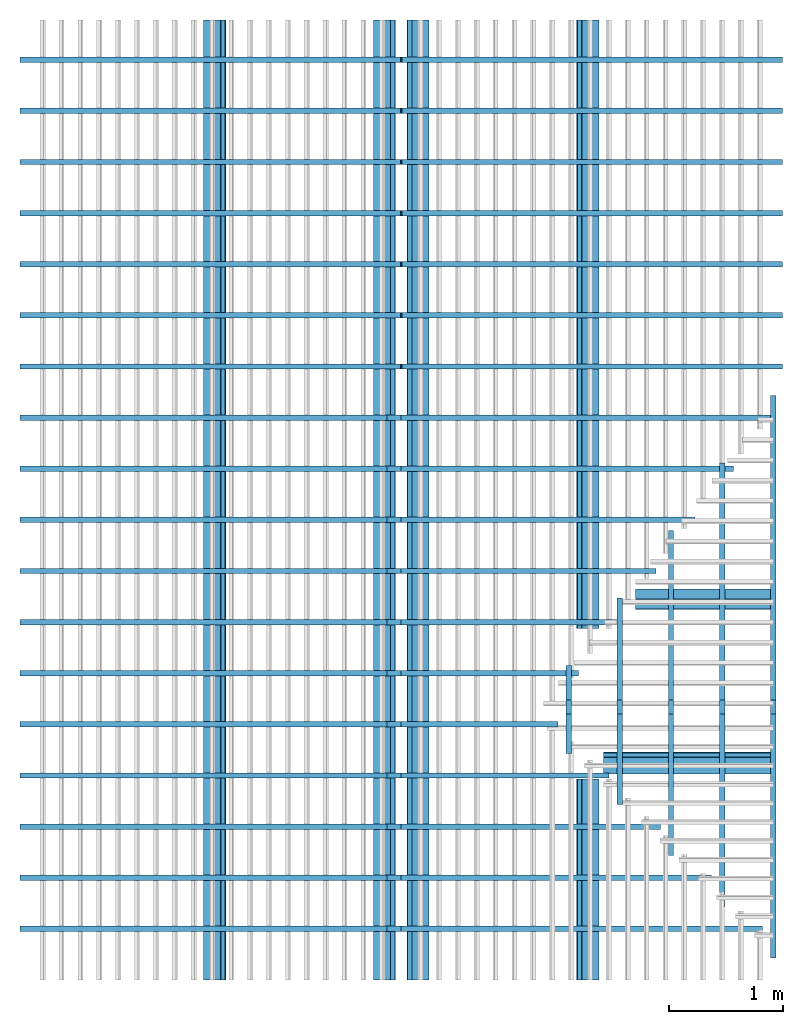
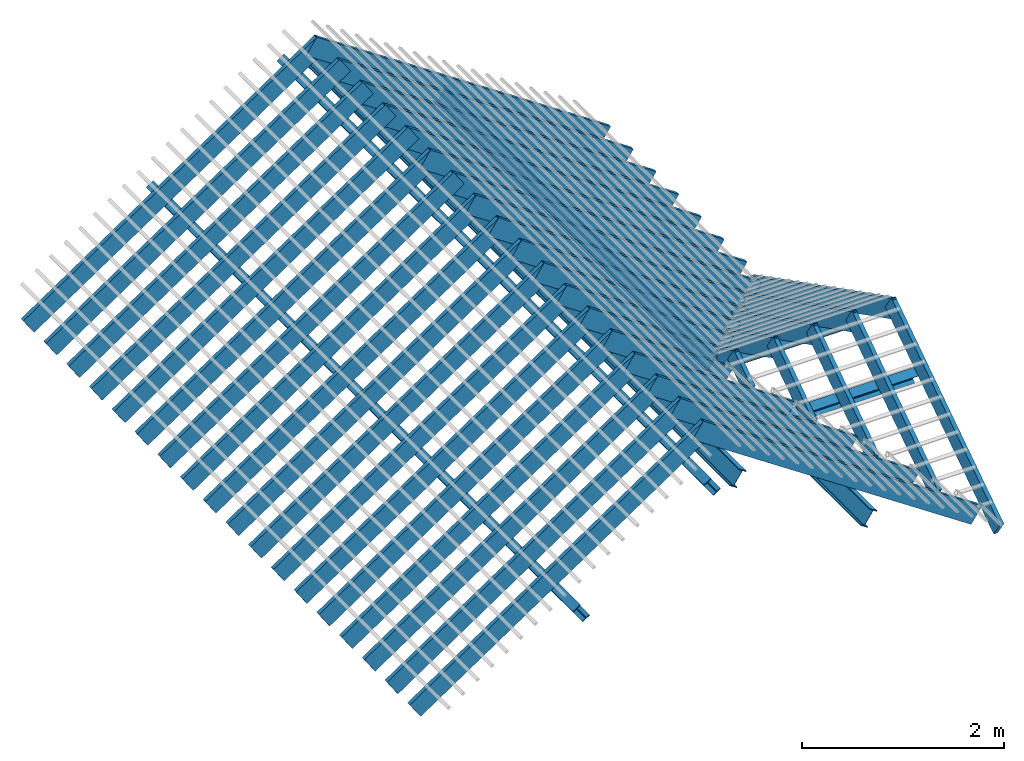
# One storey, part 1 of 3: 53 members, 10 elements without a shape of their own.
"""IFC4 building model written with IfcOpenShell, lengths in metres."""

from ifc_helpers import new_model, entity, si_unit, converted_unit, frame, frame_2d, origin_with_axes, origin_2d_with_axis, place, context, subcontext, project, library, spatial, rectangle, i_section, extrude, material, material_profile, profile_set, profile_usage, type_object, element, aggregate, save


model = new_model("IFC4")

# Units and contexts
model_context = context("Model", 3, precision=1e-05, world=origin_with_axes())
plan_context = context("Plan", 2, precision=1e-05, world=origin_2d_with_axis())
body_context = subcontext(model_context, "Body", "Model", "MODEL_VIEW")
ifc_project = project(units=[si_unit("LENGTHUNIT", "METRE"), converted_unit("PLANEANGLEUNIT", "degree", entity("IfcReal", 0.0174532925199433), si_unit("PLANEANGLEUNIT", "RADIAN"), dimensions=[0, 0, 0, 0, 0, 0, 0]), si_unit("AREAUNIT", "SQUARE_METRE"), si_unit("VOLUMEUNIT", "CUBIC_METRE")], contexts=[model_context, plan_context])
project_library_1 = library(declared=ifc_project)
project_library_2 = library(declared=ifc_project)
project_library_3 = library(declared=ifc_project)

# Site, building, storey
site_placement = place(None, frame((-0.0250487327575684, 0.0, 0.0), z_axis=(0.0, 0.0, 1.0), x_axis=(1.0, 0.0, 0.0)))
site = spatial("IfcSite", under=ifc_project, at=site_placement)
building_placement = place(site_placement, origin_with_axes())
building = spatial("IfcBuilding", under=site, at=building_placement, Name="Building")
storey_placement = place(building_placement, frame((0.0250487327575684, 0.0, 0.0), z_axis=(0.0, 0.0, 1.0), x_axis=(1.0, 0.0, 0.0)))
storey = spatial("IfcBuildingStorey", under=building, at=storey_placement, Name="Roof framing", CompositionType="ELEMENT", Elevation=0.0)

# Assemblies, members
assembly_1_placement = place(storey_placement, origin_with_axes())
assembly_1 = element("IfcElementAssembly", 1, at=assembly_1_placement, inside=storey, Name="purlins")
assembly_2_placement = place(assembly_1_placement, frame((1.27500009536743, -6.61744490042422e-24, 2.40000009536743), z_axis=(0.557621447781006, -6.78052809385821e-09, 0.830095368602075), x_axis=(1.21597333116231e-08, 1.0, -6.86638795477696e-25)))
assembly_2 = element("IfcElementAssembly", 2, at=assembly_2_placement, Name="purlins")
ifc_material_1 = material(Name="Hot Rolled Steel")
ifc_material_profile_1 = material_profile(ifc_material_1, i_section(OverallWidth=0.1, OverallDepth=0.2, WebThickness=0.005, FlangeThickness=0.01, FilletRadius=0.005, at=frame_2d((0.0, -0.25), x_axis=(1.0, 0.0))))
ifc_profile_set_1 = profile_set([ifc_material_profile_1])
ifc_profile_usage_1 = profile_usage(ifc_profile_set_1)
member_type_1 = type_object("IfcMemberType", Name="purlin", PredefinedType="PURLIN", material=ifc_profile_set_1)
member_1_placement = place(assembly_2_placement, frame((1.76917151168791, 1.8, 0.0), z_axis=(-1.0, 1.25507673201836e-16, 0.0), x_axis=(-1.25507673201836e-16, -1.0, 0.0)))
member_1 = element("IfcMember", 3, at=member_1_placement, type_object=member_type_1, material=ifc_profile_usage_1, Name="purlin", context=body_context, shape_type="SweptSolid", body=[
    extrude(i_section(OverallWidth=0.1, OverallDepth=0.2, WebThickness=0.005, FlangeThickness=0.01, FilletRadius=0.005, at=frame_2d((0.0, -0.25), x_axis=(1.0, 0.0))), origin_with_axes(), (0.0, 0.0, 1.0), 1.76917155151103),
])
ifc_profile_usage_2 = profile_usage(ifc_profile_set_1)
member_2_placement = place(assembly_2_placement, frame((8.44999980926514, 3.6, 0.0), z_axis=(-1.0, 0.0, 0.0), x_axis=(0.0, -1.0, 0.0)))
member_2 = element("IfcMember", 4, at=member_2_placement, type_object=member_type_1, material=ifc_profile_usage_2, Name="purlin", context=body_context, shape_type="SweptSolid", body=[
    extrude(i_section(OverallWidth=0.1, OverallDepth=0.2, WebThickness=0.005, FlangeThickness=0.01, FilletRadius=0.005, at=frame_2d((0.0, -0.25), x_axis=(1.0, 0.0))), origin_with_axes(), (0.0, 0.0, 1.0), 8.44999984908826),
])
ifc_profile_usage_3 = profile_usage(ifc_profile_set_1)
member_3_placement = place(assembly_2_placement, frame((8.44999980926514, 1.8, 0.0), z_axis=(-1.0, 0.0, 0.0), x_axis=(0.0, -1.0, 0.0)))
member_3 = element("IfcMember", 5, at=member_3_placement, type_object=member_type_1, material=ifc_profile_usage_3, Name="purlin", context=body_context, shape_type="SweptSolid", body=[
    extrude(i_section(OverallWidth=0.1, OverallDepth=0.2, WebThickness=0.005, FlangeThickness=0.01, FilletRadius=0.005, at=frame_2d((0.0, -0.25), x_axis=(1.0, 0.0))), origin_with_axes(), (0.0, 0.0, 1.0), 5.35502062257291),
])
aggregate(assembly_2, [member_1, member_2, member_3])
assembly_3_placement = place(assembly_1_placement, frame((-5.27499914169312, 0.0, 2.40000009536743), z_axis=(-0.557621451915285, 0.0, 0.830095365824849), x_axis=(0.0, -1.0, 0.0)))
assembly_3 = element("IfcElementAssembly", 6, at=assembly_3_placement, Name="purlins")
ifc_profile_usage_4 = profile_usage(ifc_profile_set_1)
member_4_placement = place(assembly_3_placement, frame((0.0, 1.8, 0.0), z_axis=(-1.0, 0.0, 0.0), x_axis=(0.0, -1.0, 0.0)))
member_4 = element("IfcMember", 7, at=member_4_placement, type_object=member_type_1, material=ifc_profile_usage_4, Name="purlin", context=body_context, shape_type="SweptSolid", body=[
    extrude(i_section(OverallWidth=0.1, OverallDepth=0.2, WebThickness=0.005, FlangeThickness=0.01, FilletRadius=0.005, at=frame_2d((0.0, -0.25), x_axis=(1.0, 0.0))), origin_with_axes(), (0.0, 0.0, 1.0), 8.44999980926514),
])
ifc_profile_usage_5 = profile_usage(ifc_profile_set_1)
member_5_placement = place(assembly_3_placement, frame((0.0, 3.6, 0.0), z_axis=(-1.0, 0.0, 0.0), x_axis=(0.0, -1.0, 0.0)))
member_5 = element("IfcMember", 8, at=member_5_placement, type_object=member_type_1, material=ifc_profile_usage_5, Name="purlin", context=body_context, shape_type="SweptSolid", body=[
    extrude(i_section(OverallWidth=0.1, OverallDepth=0.2, WebThickness=0.005, FlangeThickness=0.01, FilletRadius=0.005, at=frame_2d((0.0, -0.25), x_axis=(1.0, 0.0))), origin_with_axes(), (0.0, 0.0, 1.0), 8.44999980926514),
])
aggregate(assembly_3, [member_4, member_5])
assembly_4_placement = place(assembly_1_placement, frame((1.27500009536743, 5.06999969482422, 2.40000009536743), z_axis=(-1.8134071260532e-16, 0.453056810096847, 0.891481646936643), x_axis=(-1.0, -4.00260427751998e-16, -2.19767193434487e-32)))
assembly_4 = element("IfcElementAssembly", 9, at=assembly_4_placement, Name="purlins")
ifc_profile_usage_6 = profile_usage(ifc_profile_set_1)
member_6_placement = place(assembly_4_placement, frame((1.2139864578885, 1.8, 0.0), z_axis=(-1.0, 3.65810213955009e-16, 0.0), x_axis=(-3.65810213955009e-16, -1.0, 0.0)))
member_6 = element("IfcMember", 10, at=member_6_placement, type_object=member_type_1, material=ifc_profile_usage_6, Name="purlin", context=body_context, shape_type="SweptSolid", body=[
    extrude(i_section(OverallWidth=0.1, OverallDepth=0.2, WebThickness=0.005, FlangeThickness=0.01, FilletRadius=0.005, at=frame_2d((0.0, -0.25), x_axis=(1.0, 0.0))), origin_with_axes(), (0.0, 0.0, 1.0), 1.21398799953869),
])
aggregate(assembly_4, [member_6])
assembly_5_placement = place(assembly_1_placement, frame((1.27500009536743, 0.274999976158142, 2.40000009536743), z_axis=(-5.93234342970621e-17, -0.55762137886684, 0.830095414895567), x_axis=(1.0, -1.0638658513706e-16, 0.0)))
assembly_5 = element("IfcElementAssembly", 11, at=assembly_5_placement, Name="purlins")
aggregate(assembly_1, [assembly_2, assembly_3, assembly_4, assembly_5])
ifc_profile_usage_7 = profile_usage(ifc_profile_set_1)
member_7_placement = place(assembly_5_placement, frame((1.8974598461341e-06, 1.8, 0.0), z_axis=(-1.0, 2.97213871125409e-16, 0.0), x_axis=(-2.97213871125409e-16, -1.0, 0.0)))
member_7 = element("IfcMember", 12, at=member_7_placement, type_object=member_type_1, material=ifc_profile_usage_7, Name="purlin", context=body_context, shape_type="SweptSolid", body=[
    extrude(i_section(OverallWidth=0.1, OverallDepth=0.2, WebThickness=0.005, FlangeThickness=0.01, FilletRadius=0.005, at=frame_2d((0.0, -0.25), x_axis=(1.0, 0.0))), origin_with_axes(), (0.0, 0.0, 1.0), 1.49417390301639),
])
aggregate(assembly_5, [member_7])

assembly_6_placement = place(storey_placement, origin_with_axes())
assembly_6 = element("IfcElementAssembly", 13, at=assembly_6_placement, inside=storey, Name="joists")
assembly_7_placement = place(assembly_6_placement, frame((1.27500009536743, -6.61744490042422e-24, 2.40000009536743), z_axis=(0.557621447781006, -6.78052809385821e-09, 0.830095368602075), x_axis=(1.21597333116231e-08, 1.0, -6.86638795477696e-25)))
assembly_7 = element("IfcElementAssembly", 14, at=assembly_7_placement, Name="joists")
ifc_material_2 = material(Name="C24 Wood")
ifc_material_profile_2 = material_profile(ifc_material_2, rectangle(XDim=0.047, YDim=0.22, at=frame_2d((0.0, -0.04), x_axis=(1.0, 0.0))))
ifc_profile_set_2 = profile_set([ifc_material_profile_2])
ifc_profile_usage_8 = profile_usage(ifc_profile_set_2)
member_type_2 = type_object("IfcMemberType", Name="joist", PredefinedType="RAFTER", material=ifc_profile_set_2)
member_8_placement = place(assembly_7_placement, frame((0.45, 3.99532944546262, 0.0), z_axis=(-5.9457489813241e-17, -1.0, 0.0), x_axis=(1.0, -5.9457489813241e-17, 0.0)))
member_8 = element("IfcMember", 15, at=member_8_placement, type_object=member_type_2, material=ifc_profile_usage_8, Name="joist", context=body_context, shape_type="SweptSolid", body=[
    extrude(rectangle(XDim=0.047, YDim=0.22, at=frame_2d((0.0, -0.04), x_axis=(1.0, 0.0))), origin_with_axes(), (0.0, 0.0, 1.0), 3.83451024626981),
])
ifc_profile_usage_9 = profile_usage(ifc_profile_set_2)
member_9_placement = place(assembly_7_placement, frame((0.9, 3.99532944546262, 0.0), z_axis=(-3.47770234890074e-17, -1.0, 0.0), x_axis=(1.0, -3.47770234890074e-17, 0.0)))
member_9 = element("IfcMember", 16, at=member_9_placement, type_object=member_type_2, material=ifc_profile_usage_9, Name="joist", context=body_context, shape_type="SweptSolid", body=[
    extrude(rectangle(XDim=0.047, YDim=0.22, at=frame_2d((0.0, -0.04), x_axis=(1.0, 0.0))), origin_with_axes(), (0.0, 0.0, 1.0), 3.29240381505359),
])
ifc_profile_usage_10 = profile_usage(ifc_profile_set_2)
member_10_placement = place(assembly_7_placement, frame((1.35, 3.99532944546262, 0.0), z_axis=(-8.37810150208624e-17, -1.0, 0.0), x_axis=(1.0, -8.37810150208624e-17, 0.0)))
member_10 = element("IfcMember", 17, at=member_10_placement, type_object=member_type_2, material=ifc_profile_usage_10, Name="joist", context=body_context, shape_type="SweptSolid", body=[
    extrude(rectangle(XDim=0.047, YDim=0.22, at=frame_2d((0.0, -0.04), x_axis=(1.0, 0.0))), origin_with_axes(), (0.0, 0.0, 1.0), 2.75029738383737),
])
ifc_profile_usage_11 = profile_usage(ifc_profile_set_2)
member_11_placement = place(assembly_7_placement, frame((1.8, 3.99532944546262, 0.0), z_axis=(-1.05324711999622e-16, -1.0, 0.0), x_axis=(1.0, -1.05324711999622e-16, 0.0)))
member_11 = element("IfcMember", 18, at=member_11_placement, type_object=member_type_2, material=ifc_profile_usage_11, Name="joist", context=body_context, shape_type="SweptSolid", body=[
    extrude(rectangle(XDim=0.047, YDim=0.22, at=frame_2d((0.0, -0.04), x_axis=(1.0, 0.0))), origin_with_axes(), (0.0, 0.0, 1.0), 2.20819095262115),
])
ifc_profile_usage_12 = profile_usage(ifc_profile_set_2)
member_12_placement = place(assembly_7_placement, frame((2.25, 3.99532944546262, 0.0), z_axis=(-2.83566566031615e-16, -1.0, 0.0), x_axis=(1.0, -2.83566566031615e-16, 0.0)))
member_12 = element("IfcMember", 19, at=member_12_placement, type_object=member_type_2, material=ifc_profile_usage_12, Name="joist", context=body_context, shape_type="SweptSolid", body=[
    extrude(rectangle(XDim=0.047, YDim=0.22, at=frame_2d((0.0, -0.04), x_axis=(1.0, 0.0))), origin_with_axes(), (0.0, 0.0, 1.0), 1.66608452140494),
])
ifc_profile_usage_13 = profile_usage(ifc_profile_set_2)
member_13_placement = place(assembly_7_placement, frame((2.7, 3.99532944546262, 0.0), z_axis=(0.0, -1.0, 0.0), x_axis=(1.0, 0.0, 0.0)))
member_13 = element("IfcMember", 20, at=member_13_placement, type_object=member_type_2, material=ifc_profile_usage_13, Name="joist", context=body_context, shape_type="SweptSolid", body=[
    extrude(rectangle(XDim=0.047, YDim=0.22, at=frame_2d((0.0, -0.04), x_axis=(1.0, 0.0))), origin_with_axes(), (0.0, 0.0, 1.0), 1.88535216274302),
])
ifc_profile_usage_14 = profile_usage(ifc_profile_set_2)
member_14_placement = place(assembly_7_placement, frame((3.15, 3.99532944546262, 0.0), z_axis=(-2.02274822579913e-16, -1.0, 0.0), x_axis=(1.0, -2.02274822579913e-16, 0.0)))
member_14 = element("IfcMember", 21, at=member_14_placement, type_object=member_type_2, material=ifc_profile_usage_14, Name="joist", context=body_context, shape_type="SweptSolid", body=[
    extrude(rectangle(XDim=0.047, YDim=0.22, at=frame_2d((0.0, -0.04), x_axis=(1.0, 0.0))), origin_with_axes(), (0.0, 0.0, 1.0), 2.29547447470688),
])
ifc_profile_usage_15 = profile_usage(ifc_profile_set_2)
member_15_placement = place(assembly_7_placement, frame((3.6, 3.99532944546262, 0.0), z_axis=(-1.70436658550493e-16, -1.0, 0.0), x_axis=(1.0, -1.70436658550493e-16, 0.0)))
member_15 = element("IfcMember", 22, at=member_15_placement, type_object=member_type_2, material=ifc_profile_usage_15, Name="joist", context=body_context, shape_type="SweptSolid", body=[
    extrude(rectangle(XDim=0.047, YDim=0.22, at=frame_2d((0.0, -0.04), x_axis=(1.0, 0.0))), origin_with_axes(), (0.0, 0.0, 1.0), 2.70559678667074),
])
ifc_profile_usage_16 = profile_usage(ifc_profile_set_2)
member_16_placement = place(assembly_7_placement, frame((4.05, 3.99532944546262, 0.0), z_axis=(0.0, -1.0, 0.0), x_axis=(1.0, 0.0, 0.0)))
member_16 = element("IfcMember", 23, at=member_16_placement, type_object=member_type_2, material=ifc_profile_usage_16, Name="joist", context=body_context, shape_type="SweptSolid", body=[
    extrude(rectangle(XDim=0.047, YDim=0.22, at=frame_2d((0.0, -0.04), x_axis=(1.0, 0.0))), origin_with_axes(), (0.0, 0.0, 1.0), 3.11571909863461),
])
ifc_profile_usage_17 = profile_usage(ifc_profile_set_2)
member_17_placement = place(assembly_7_placement, frame((4.5, 3.99532944546262, 0.0), z_axis=(0.0, -1.0, 0.0), x_axis=(1.0, 0.0, 0.0)))
member_17 = element("IfcMember", 24, at=member_17_placement, type_object=member_type_2, material=ifc_profile_usage_17, Name="joist", context=body_context, shape_type="SweptSolid", body=[
    extrude(rectangle(XDim=0.047, YDim=0.22, at=frame_2d((0.0, -0.04), x_axis=(1.0, 0.0))), origin_with_axes(), (0.0, 0.0, 1.0), 3.52584141059847),
])
ifc_profile_usage_18 = profile_usage(ifc_profile_set_2)
member_18_placement = place(assembly_7_placement, frame((4.95, 3.99532944546262, 0.0), z_axis=(0.0, -1.0, 0.0), x_axis=(1.0, 0.0, 0.0)))
member_18 = element("IfcMember", 25, at=member_18_placement, type_object=member_type_2, material=ifc_profile_usage_18, Name="joist", context=body_context, shape_type="SweptSolid", body=[
    extrude(rectangle(XDim=0.047, YDim=0.22, at=frame_2d((0.0, -0.04), x_axis=(1.0, 0.0))), origin_with_axes(), (0.0, 0.0, 1.0), 3.93596372256233),
])
ifc_profile_usage_19 = profile_usage(ifc_profile_set_2)
member_19_placement = place(assembly_7_placement, frame((5.4, 3.99532944546262, 0.0), z_axis=(0.0, -1.0, 0.0), x_axis=(1.0, 0.0, 0.0)))
member_19 = element("IfcMember", 26, at=member_19_placement, type_object=member_type_2, material=ifc_profile_usage_19, Name="joist", context=body_context, shape_type="SweptSolid", body=[
    extrude(rectangle(XDim=0.047, YDim=0.22, at=frame_2d((0.0, -0.04), x_axis=(1.0, 0.0))), origin_with_axes(), (0.0, 0.0, 1.0), 4.04532944546262),
])
ifc_profile_usage_20 = profile_usage(ifc_profile_set_2)
member_20_placement = place(assembly_7_placement, frame((5.85, 3.99532944546262, 0.0), z_axis=(0.0, -1.0, 0.0), x_axis=(1.0, 0.0, 0.0)))
member_20 = element("IfcMember", 27, at=member_20_placement, type_object=member_type_2, material=ifc_profile_usage_20, Name="joist", context=body_context, shape_type="SweptSolid", body=[
    extrude(rectangle(XDim=0.047, YDim=0.22, at=frame_2d((0.0, -0.04), x_axis=(1.0, 0.0))), origin_with_axes(), (0.0, 0.0, 1.0), 4.04532944546262),
])
ifc_profile_usage_21 = profile_usage(ifc_profile_set_2)
member_21_placement = place(assembly_7_placement, frame((6.3, 3.99532944546262, 0.0), z_axis=(0.0, -1.0, 0.0), x_axis=(1.0, 0.0, 0.0)))
member_21 = element("IfcMember", 28, at=member_21_placement, type_object=member_type_2, material=ifc_profile_usage_21, Name="joist", context=body_context, shape_type="SweptSolid", body=[
    extrude(rectangle(XDim=0.047, YDim=0.22, at=frame_2d((0.0, -0.04), x_axis=(1.0, 0.0))), origin_with_axes(), (0.0, 0.0, 1.0), 4.04532944546262),
])
ifc_profile_usage_22 = profile_usage(ifc_profile_set_2)
member_22_placement = place(assembly_7_placement, frame((6.75, 3.99532944546262, 0.0), z_axis=(0.0, -1.0, 0.0), x_axis=(1.0, 0.0, 0.0)))
member_22 = element("IfcMember", 29, at=member_22_placement, type_object=member_type_2, material=ifc_profile_usage_22, Name="joist", context=body_context, shape_type="SweptSolid", body=[
    extrude(rectangle(XDim=0.047, YDim=0.22, at=frame_2d((0.0, -0.04), x_axis=(1.0, 0.0))), origin_with_axes(), (0.0, 0.0, 1.0), 4.04532944546262),
])
ifc_profile_usage_23 = profile_usage(ifc_profile_set_2)
member_23_placement = place(assembly_7_placement, frame((7.2, 3.99532944546262, 0.0), z_axis=(0.0, -1.0, 0.0), x_axis=(1.0, 0.0, 0.0)))
member_23 = element("IfcMember", 30, at=member_23_placement, type_object=member_type_2, material=ifc_profile_usage_23, Name="joist", context=body_context, shape_type="SweptSolid", body=[
    extrude(rectangle(XDim=0.047, YDim=0.22, at=frame_2d((0.0, -0.04), x_axis=(1.0, 0.0))), origin_with_axes(), (0.0, 0.0, 1.0), 4.04532944546262),
])
ifc_profile_usage_24 = profile_usage(ifc_profile_set_2)
member_24_placement = place(assembly_7_placement, frame((7.65, 3.99532944546262, 0.0), z_axis=(0.0, -1.0, 0.0), x_axis=(1.0, 0.0, 0.0)))
member_24 = element("IfcMember", 31, at=member_24_placement, type_object=member_type_2, material=ifc_profile_usage_24, Name="joist", context=body_context, shape_type="SweptSolid", body=[
    extrude(rectangle(XDim=0.047, YDim=0.22, at=frame_2d((0.0, -0.04), x_axis=(1.0, 0.0))), origin_with_axes(), (0.0, 0.0, 1.0), 4.04532944546262),
])
ifc_profile_usage_25 = profile_usage(ifc_profile_set_2)
member_25_placement = place(assembly_7_placement, frame((8.1, 3.99532944546262, 0.0), z_axis=(0.0, -1.0, 0.0), x_axis=(1.0, 0.0, 0.0)))
member_25 = element("IfcMember", 32, at=member_25_placement, type_object=member_type_2, material=ifc_profile_usage_25, Name="joist", context=body_context, shape_type="SweptSolid", body=[
    extrude(rectangle(XDim=0.047, YDim=0.22, at=frame_2d((0.0, -0.04), x_axis=(1.0, 0.0))), origin_with_axes(), (0.0, 0.0, 1.0), 4.04532944546262),
])
aggregate(assembly_7, [member_8, member_9, member_10, member_11, member_12, member_13, member_14, member_15, member_16, member_17, member_18, member_19, member_20, member_21, member_22, member_23, member_24, member_25])
assembly_8_placement = place(assembly_6_placement, frame((-5.27499914169312, 0.0, 2.40000009536743), z_axis=(-0.557621451915285, 0.0, 0.830095365824849), x_axis=(0.0, -1.0, 0.0)))
assembly_8 = element("IfcElementAssembly", 33, at=assembly_8_placement, Name="joists")
ifc_profile_usage_26 = profile_usage(ifc_profile_set_2)
member_26_placement = place(assembly_8_placement, frame((-0.449999999999999, 3.99532936017053, 0.0), z_axis=(-5.62803722210492e-17, -1.0, 0.0), x_axis=(1.0, -5.62803722210492e-17, 0.0)))
member_26 = element("IfcMember", 34, at=member_26_placement, type_object=member_type_2, material=ifc_profile_usage_26, Name="joist", context=body_context, shape_type="SweptSolid", body=[
    extrude(rectangle(XDim=0.047, YDim=0.22, at=frame_2d((0.0, -0.04), x_axis=(1.0, 0.0))), origin_with_axes(), (0.0, 0.0, 1.0), 4.04532936017053),
])
ifc_profile_usage_27 = profile_usage(ifc_profile_set_2)
member_27_placement = place(assembly_8_placement, frame((-0.899999999999999, 3.99532936017053, 0.0), z_axis=(-5.62803722210492e-17, -1.0, 0.0), x_axis=(1.0, -5.62803722210492e-17, 0.0)))
member_27 = element("IfcMember", 35, at=member_27_placement, type_object=member_type_2, material=ifc_profile_usage_27, Name="joist", context=body_context, shape_type="SweptSolid", body=[
    extrude(rectangle(XDim=0.047, YDim=0.22, at=frame_2d((0.0, -0.04), x_axis=(1.0, 0.0))), origin_with_axes(), (0.0, 0.0, 1.0), 4.04532936017053),
])
ifc_profile_usage_28 = profile_usage(ifc_profile_set_2)
member_28_placement = place(assembly_8_placement, frame((-1.35, 3.99532936017053, 0.0), z_axis=(-5.62803722210492e-17, -1.0, 0.0), x_axis=(1.0, -5.62803722210492e-17, 0.0)))
member_28 = element("IfcMember", 36, at=member_28_placement, type_object=member_type_2, material=ifc_profile_usage_28, Name="joist", context=body_context, shape_type="SweptSolid", body=[
    extrude(rectangle(XDim=0.047, YDim=0.22, at=frame_2d((0.0, -0.04), x_axis=(1.0, 0.0))), origin_with_axes(), (0.0, 0.0, 1.0), 4.04532936017053),
])
ifc_profile_usage_29 = profile_usage(ifc_profile_set_2)
member_29_placement = place(assembly_8_placement, frame((-1.8, 3.99532936017053, 0.0), z_axis=(-5.62803722210492e-17, -1.0, 0.0), x_axis=(1.0, -5.62803722210492e-17, 0.0)))
member_29 = element("IfcMember", 37, at=member_29_placement, type_object=member_type_2, material=ifc_profile_usage_29, Name="joist", context=body_context, shape_type="SweptSolid", body=[
    extrude(rectangle(XDim=0.047, YDim=0.22, at=frame_2d((0.0, -0.04), x_axis=(1.0, 0.0))), origin_with_axes(), (0.0, 0.0, 1.0), 4.04532936017053),
])
ifc_profile_usage_30 = profile_usage(ifc_profile_set_2)
member_30_placement = place(assembly_8_placement, frame((-2.25, 3.99532936017053, 0.0), z_axis=(-1.12560744442098e-16, -1.0, 0.0), x_axis=(1.0, -1.12560744442098e-16, 0.0)))
member_30 = element("IfcMember", 38, at=member_30_placement, type_object=member_type_2, material=ifc_profile_usage_30, Name="joist", context=body_context, shape_type="SweptSolid", body=[
    extrude(rectangle(XDim=0.047, YDim=0.22, at=frame_2d((0.0, -0.04), x_axis=(1.0, 0.0))), origin_with_axes(), (0.0, 0.0, 1.0), 4.04532936017053),
])
ifc_profile_usage_31 = profile_usage(ifc_profile_set_2)
member_31_placement = place(assembly_8_placement, frame((-2.7, 3.99532936017053, 0.0), z_axis=(-1.12560744442098e-16, -1.0, 0.0), x_axis=(1.0, -1.12560744442098e-16, 0.0)))
member_31 = element("IfcMember", 39, at=member_31_placement, type_object=member_type_2, material=ifc_profile_usage_31, Name="joist", context=body_context, shape_type="SweptSolid", body=[
    extrude(rectangle(XDim=0.047, YDim=0.22, at=frame_2d((0.0, -0.04), x_axis=(1.0, 0.0))), origin_with_axes(), (0.0, 0.0, 1.0), 4.04532936017053),
])
ifc_profile_usage_32 = profile_usage(ifc_profile_set_2)
member_32_placement = place(assembly_8_placement, frame((-3.15, 3.99532936017053, 0.0), z_axis=(-1.12560744442098e-16, -1.0, 0.0), x_axis=(1.0, -1.12560744442098e-16, 0.0)))
member_32 = element("IfcMember", 40, at=member_32_placement, type_object=member_type_2, material=ifc_profile_usage_32, Name="joist", context=body_context, shape_type="SweptSolid", body=[
    extrude(rectangle(XDim=0.047, YDim=0.22, at=frame_2d((0.0, -0.04), x_axis=(1.0, 0.0))), origin_with_axes(), (0.0, 0.0, 1.0), 4.04532936017053),
])
ifc_profile_usage_33 = profile_usage(ifc_profile_set_2)
member_33_placement = place(assembly_8_placement, frame((-3.6, 3.99532936017053, 0.0), z_axis=(-1.12560744442098e-16, -1.0, 0.0), x_axis=(1.0, -1.12560744442098e-16, 0.0)))
member_33 = element("IfcMember", 41, at=member_33_placement, type_object=member_type_2, material=ifc_profile_usage_33, Name="joist", context=body_context, shape_type="SweptSolid", body=[
    extrude(rectangle(XDim=0.047, YDim=0.22, at=frame_2d((0.0, -0.04), x_axis=(1.0, 0.0))), origin_with_axes(), (0.0, 0.0, 1.0), 4.04532936017053),
])
ifc_profile_usage_34 = profile_usage(ifc_profile_set_2)
member_34_placement = place(assembly_8_placement, frame((-4.05, 3.99532936017053, 0.0), z_axis=(0.0, -1.0, 0.0), x_axis=(1.0, 0.0, 0.0)))
member_34 = element("IfcMember", 42, at=member_34_placement, type_object=member_type_2, material=ifc_profile_usage_34, Name="joist", context=body_context, shape_type="SweptSolid", body=[
    extrude(rectangle(XDim=0.047, YDim=0.22, at=frame_2d((0.0, -0.04), x_axis=(1.0, 0.0))), origin_with_axes(), (0.0, 0.0, 1.0), 4.04532936017053),
])
ifc_profile_usage_35 = profile_usage(ifc_profile_set_2)
member_35_placement = place(assembly_8_placement, frame((-4.5, 3.99532936017053, 0.0), z_axis=(0.0, -1.0, 0.0), x_axis=(1.0, 0.0, 0.0)))
member_35 = element("IfcMember", 43, at=member_35_placement, type_object=member_type_2, material=ifc_profile_usage_35, Name="joist", context=body_context, shape_type="SweptSolid", body=[
    extrude(rectangle(XDim=0.047, YDim=0.22, at=frame_2d((0.0, -0.04), x_axis=(1.0, 0.0))), origin_with_axes(), (0.0, 0.0, 1.0), 4.04532936017053),
])
ifc_profile_usage_36 = profile_usage(ifc_profile_set_2)
member_36_placement = place(assembly_8_placement, frame((-4.95, 3.99532936017053, 0.0), z_axis=(0.0, -1.0, 0.0), x_axis=(1.0, 0.0, 0.0)))
member_36 = element("IfcMember", 44, at=member_36_placement, type_object=member_type_2, material=ifc_profile_usage_36, Name="joist", context=body_context, shape_type="SweptSolid", body=[
    extrude(rectangle(XDim=0.047, YDim=0.22, at=frame_2d((0.0, -0.04), x_axis=(1.0, 0.0))), origin_with_axes(), (0.0, 0.0, 1.0), 4.04532936017053),
])
ifc_profile_usage_37 = profile_usage(ifc_profile_set_2)
member_37_placement = place(assembly_8_placement, frame((-5.4, 3.99532936017053, 0.0), z_axis=(0.0, -1.0, 0.0), x_axis=(1.0, 0.0, 0.0)))
member_37 = element("IfcMember", 45, at=member_37_placement, type_object=member_type_2, material=ifc_profile_usage_37, Name="joist", context=body_context, shape_type="SweptSolid", body=[
    extrude(rectangle(XDim=0.047, YDim=0.22, at=frame_2d((0.0, -0.04), x_axis=(1.0, 0.0))), origin_with_axes(), (0.0, 0.0, 1.0), 4.04532936017053),
])
ifc_profile_usage_38 = profile_usage(ifc_profile_set_2)
member_38_placement = place(assembly_8_placement, frame((-5.85, 3.99532936017053, 0.0), z_axis=(0.0, -1.0, 0.0), x_axis=(1.0, 0.0, 0.0)))
member_38 = element("IfcMember", 46, at=member_38_placement, type_object=member_type_2, material=ifc_profile_usage_38, Name="joist", context=body_context, shape_type="SweptSolid", body=[
    extrude(rectangle(XDim=0.047, YDim=0.22, at=frame_2d((0.0, -0.04), x_axis=(1.0, 0.0))), origin_with_axes(), (0.0, 0.0, 1.0), 4.04532936017053),
])
ifc_profile_usage_39 = profile_usage(ifc_profile_set_2)
member_39_placement = place(assembly_8_placement, frame((-6.3, 3.99532936017053, 0.0), z_axis=(0.0, -1.0, 0.0), x_axis=(1.0, 0.0, 0.0)))
member_39 = element("IfcMember", 47, at=member_39_placement, type_object=member_type_2, material=ifc_profile_usage_39, Name="joist", context=body_context, shape_type="SweptSolid", body=[
    extrude(rectangle(XDim=0.047, YDim=0.22, at=frame_2d((0.0, -0.04), x_axis=(1.0, 0.0))), origin_with_axes(), (0.0, 0.0, 1.0), 4.04532936017053),
])
ifc_profile_usage_40 = profile_usage(ifc_profile_set_2)
member_40_placement = place(assembly_8_placement, frame((-6.75, 3.99532936017053, 0.0), z_axis=(0.0, -1.0, 0.0), x_axis=(1.0, 0.0, 0.0)))
member_40 = element("IfcMember", 48, at=member_40_placement, type_object=member_type_2, material=ifc_profile_usage_40, Name="joist", context=body_context, shape_type="SweptSolid", body=[
    extrude(rectangle(XDim=0.047, YDim=0.22, at=frame_2d((0.0, -0.04), x_axis=(1.0, 0.0))), origin_with_axes(), (0.0, 0.0, 1.0), 4.04532936017053),
])
ifc_profile_usage_41 = profile_usage(ifc_profile_set_2)
member_41_placement = place(assembly_8_placement, frame((-7.2, 3.99532936017053, 0.0), z_axis=(0.0, -1.0, 0.0), x_axis=(1.0, 0.0, 0.0)))
member_41 = element("IfcMember", 49, at=member_41_placement, type_object=member_type_2, material=ifc_profile_usage_41, Name="joist", context=body_context, shape_type="SweptSolid", body=[
    extrude(rectangle(XDim=0.047, YDim=0.22, at=frame_2d((0.0, -0.04), x_axis=(1.0, 0.0))), origin_with_axes(), (0.0, 0.0, 1.0), 4.04532936017053),
])
ifc_profile_usage_42 = profile_usage(ifc_profile_set_2)
member_42_placement = place(assembly_8_placement, frame((-7.65, 3.99532936017053, 0.0), z_axis=(0.0, -1.0, 0.0), x_axis=(1.0, 0.0, 0.0)))
member_42 = element("IfcMember", 50, at=member_42_placement, type_object=member_type_2, material=ifc_profile_usage_42, Name="joist", context=body_context, shape_type="SweptSolid", body=[
    extrude(rectangle(XDim=0.047, YDim=0.22, at=frame_2d((0.0, -0.04), x_axis=(1.0, 0.0))), origin_with_axes(), (0.0, 0.0, 1.0), 4.04532936017053),
])
ifc_profile_usage_43 = profile_usage(ifc_profile_set_2)
member_43_placement = place(assembly_8_placement, frame((-8.1, 3.99532936017053, 0.0), z_axis=(0.0, -1.0, 0.0), x_axis=(1.0, 0.0, 0.0)))
member_43 = element("IfcMember", 51, at=member_43_placement, type_object=member_type_2, material=ifc_profile_usage_43, Name="joist", context=body_context, shape_type="SweptSolid", body=[
    extrude(rectangle(XDim=0.047, YDim=0.22, at=frame_2d((0.0, -0.04), x_axis=(1.0, 0.0))), origin_with_axes(), (0.0, 0.0, 1.0), 4.04532936017053),
])
aggregate(assembly_8, [member_26, member_27, member_28, member_29, member_30, member_31, member_32, member_33, member_34, member_35, member_36, member_37, member_38, member_39, member_40, member_41, member_42, member_43])
assembly_9_placement = place(assembly_6_placement, frame((1.27500009536743, 5.06999969482422, 2.40000009536743), z_axis=(-1.8134071260532e-16, 0.453056810096847, 0.891481646936643), x_axis=(-1.0, -4.00260427751998e-16, -2.19767193434487e-32)))
assembly_9 = element("IfcElementAssembly", 52, at=assembly_9_placement, Name="joists")
ifc_profile_usage_44 = profile_usage(ifc_profile_set_2)
member_44_placement = place(assembly_9_placement, frame((2.13084756852002e-17, 3.1121005295707, 0.0), z_axis=(-6.84697537329862e-18, -1.0, 0.0), x_axis=(1.0, -6.84697537329862e-18, 0.0)))
member_44 = element("IfcMember", 53, at=member_44_placement, type_object=member_type_2, material=ifc_profile_usage_44, Name="joist", context=body_context, shape_type="SweptSolid", body=[
    extrude(rectangle(XDim=0.047, YDim=0.22, at=frame_2d((0.0, -0.04), x_axis=(1.0, 0.0))), origin_with_axes(), (0.0, 0.0, 1.0), 3.1621005295707),
])
ifc_profile_usage_45 = profile_usage(ifc_profile_set_2)
member_45_placement = place(assembly_9_placement, frame((0.45, 3.1121005295707, 0.0), z_axis=(-6.95373644794119e-17, -1.0, 0.0), x_axis=(1.0, -6.95373644794119e-17, 0.0)))
member_45 = element("IfcMember", 54, at=member_45_placement, type_object=member_type_2, material=ifc_profile_usage_45, Name="joist", context=body_context, shape_type="SweptSolid", body=[
    extrude(rectangle(XDim=0.047, YDim=0.22, at=frame_2d((0.0, -0.04), x_axis=(1.0, 0.0))), origin_with_axes(), (0.0, 0.0, 1.0), 2.49487727124141),
])
ifc_profile_usage_46 = profile_usage(ifc_profile_set_2)
member_46_placement = place(assembly_9_placement, frame((0.9, 3.1121005295707, 0.0), z_axis=(-1.28523768801807e-16, -1.0, 0.0), x_axis=(1.0, -1.28523768801807e-16, 0.0)))
member_46 = element("IfcMember", 55, at=member_46_placement, type_object=member_type_2, material=ifc_profile_usage_46, Name="joist", context=body_context, shape_type="SweptSolid", body=[
    extrude(rectangle(XDim=0.047, YDim=0.22, at=frame_2d((0.0, -0.04), x_axis=(1.0, 0.0))), origin_with_axes(), (0.0, 0.0, 1.0), 1.82765401291212),
])
ifc_profile_usage_47 = profile_usage(ifc_profile_set_2)
member_47_placement = place(assembly_9_placement, frame((1.35, 3.1121005295707, 0.0), z_axis=(0.0, -1.0, 0.0), x_axis=(1.0, 0.0, 0.0)))
member_47 = element("IfcMember", 56, at=member_47_placement, type_object=member_type_2, material=ifc_profile_usage_47, Name="joist", context=body_context, shape_type="SweptSolid", body=[
    extrude(rectangle(XDim=0.047, YDim=0.22, at=frame_2d((0.0, -0.04), x_axis=(1.0, 0.0))), origin_with_axes(), (0.0, 0.0, 1.0), 1.16043075458283),
])
ifc_profile_usage_48 = profile_usage(ifc_profile_set_2)
member_48_placement = place(assembly_9_placement, frame((1.8, 3.1121005295707, 0.0), z_axis=(-5.64700843805522e-16, -1.0, 0.0), x_axis=(1.0, -5.64700843805522e-16, 0.0)))
member_48 = element("IfcMember", 57, at=member_48_placement, type_object=member_type_2, material=ifc_profile_usage_48, Name="joist", context=body_context, shape_type="SweptSolid", body=[
    extrude(rectangle(XDim=0.047, YDim=0.22, at=frame_2d((0.0, -0.04), x_axis=(1.0, 0.0))), origin_with_axes(), (0.0, 0.0, 1.0), 0.493207496253541),
])
aggregate(assembly_9, [member_44, member_45, member_46, member_47, member_48])
assembly_10_placement = place(assembly_6_placement, frame((1.27500009536743, 0.274999976158142, 2.40000009536743), z_axis=(-5.93234342970621e-17, -0.55762137886684, 0.830095414895567), x_axis=(1.0, -1.0638658513706e-16, 0.0)))
assembly_10 = element("IfcElementAssembly", 58, at=assembly_10_placement, Name="joists")
aggregate(assembly_6, [assembly_7, assembly_8, assembly_9, assembly_10])
ifc_profile_usage_49 = profile_usage(ifc_profile_set_2)
member_49_placement = place(assembly_10_placement, frame((4.21479264635313e-17, 2.53789869022303, 0.0), z_axis=(-1.66074109364182e-17, -1.0, 0.0), x_axis=(1.0, -1.66074109364182e-17, 0.0)))
member_49 = element("IfcMember", 59, at=member_49_placement, type_object=member_type_2, material=ifc_profile_usage_49, Name="joist", context=body_context, shape_type="SweptSolid", body=[
    extrude(rectangle(XDim=0.047, YDim=0.22, at=frame_2d((0.0, -0.04), x_axis=(1.0, 0.0))), origin_with_axes(), (0.0, 0.0, 1.0), 2.58789869022302),
])
ifc_profile_usage_50 = profile_usage(ifc_profile_set_2)
member_50_placement = place(assembly_10_placement, frame((-0.45, 2.53789869022303, 0.0), z_axis=(-4.27932217324875e-16, -1.0, 0.0), x_axis=(1.0, -4.27932217324875e-16, 0.0)))
member_50 = element("IfcMember", 60, at=member_50_placement, type_object=member_type_2, material=ifc_profile_usage_50, Name="joist", context=body_context, shape_type="SweptSolid", body=[
    extrude(rectangle(XDim=0.047, YDim=0.22, at=frame_2d((0.0, -0.04), x_axis=(1.0, 0.0))), origin_with_axes(), (0.0, 0.0, 1.0), 2.04579242870309),
])
ifc_profile_usage_51 = profile_usage(ifc_profile_set_2)
member_51_placement = place(assembly_10_placement, frame((-0.9, 2.53789869022303, 0.0), z_axis=(-4.74560361388939e-16, -1.0, 0.0), x_axis=(1.0, -4.74560361388939e-16, 0.0)))
member_51 = element("IfcMember", 61, at=member_51_placement, type_object=member_type_2, material=ifc_profile_usage_51, Name="joist", context=body_context, shape_type="SweptSolid", body=[
    extrude(rectangle(XDim=0.047, YDim=0.22, at=frame_2d((0.0, -0.04), x_axis=(1.0, 0.0))), origin_with_axes(), (0.0, 0.0, 1.0), 1.50368616718316),
])
ifc_profile_usage_52 = profile_usage(ifc_profile_set_2)
member_52_placement = place(assembly_10_placement, frame((-1.35, 2.53789869022303, 0.0), z_axis=(-2.57717947535123e-16, -1.0, 0.0), x_axis=(1.0, -2.57717947535123e-16, 0.0)))
member_52 = element("IfcMember", 62, at=member_52_placement, type_object=member_type_2, material=ifc_profile_usage_52, Name="joist", context=body_context, shape_type="SweptSolid", body=[
    extrude(rectangle(XDim=0.047, YDim=0.22, at=frame_2d((0.0, -0.04), x_axis=(1.0, 0.0))), origin_with_axes(), (0.0, 0.0, 1.0), 0.961579905663225),
])
ifc_profile_usage_53 = profile_usage(ifc_profile_set_2)
member_53_placement = place(assembly_10_placement, frame((-1.8, 2.53789869022303, 0.0), z_axis=(-6.95032623177639e-16, -1.0, 0.0), x_axis=(1.0, -6.95032623177639e-16, 0.0)))
member_53 = element("IfcMember", 63, at=member_53_placement, type_object=member_type_2, material=ifc_profile_usage_53, Name="joist", context=body_context, shape_type="SweptSolid", body=[
    extrude(rectangle(XDim=0.047, YDim=0.22, at=frame_2d((0.0, -0.04), x_axis=(1.0, 0.0))), origin_with_axes(), (0.0, 0.0, 1.0), 0.419473644143291),
])
aggregate(assembly_10, [member_49, member_50, member_51, member_52, member_53])

save(model, "model.ifc")
